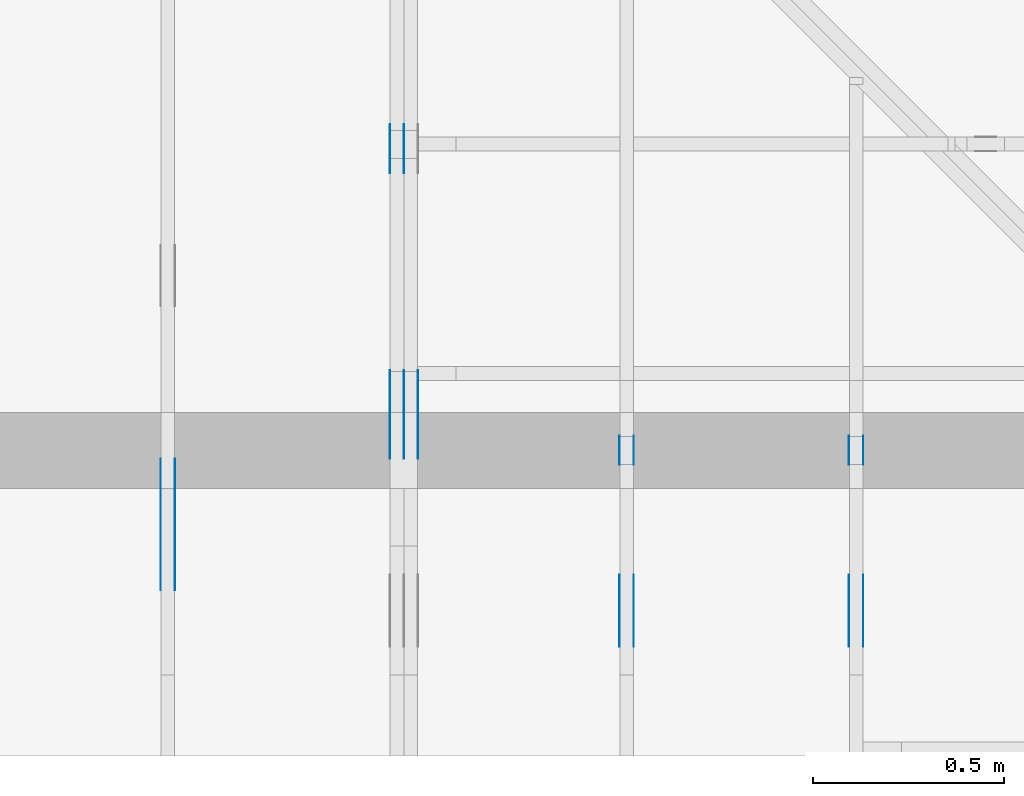
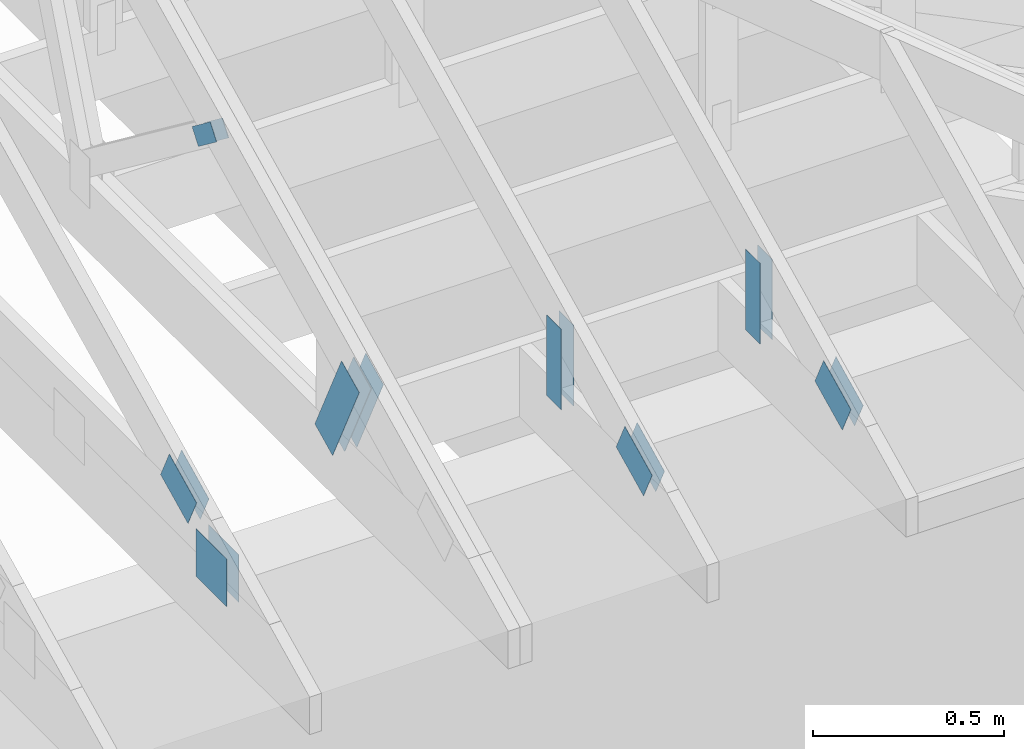
# One storey, part 113 of 159: 19 plates, 4 elements without a shape of their own.
"""IFC2X3 building model written with IfcOpenShell, lengths in millimetres."""

from ifc_helpers import new_model, si_unit, frame, origin, origin_with_axes, origin_2d, place, context, project, spatial, faceted_brep, element, aggregate, save


model = new_model("IFC2X3")

# Units and contexts
model_context = context("Model", 3, precision=1e-05, world=origin())
plan_context = context("Plan", 2, precision=1e-05, world=origin_2d())
ifc_project = project(units=[si_unit("LENGTHUNIT", "METRE", prefix="MILLI"), si_unit("AREAUNIT", "SQUARE_METRE"), si_unit("VOLUMEUNIT", "CUBIC_METRE"), si_unit("SOLIDANGLEUNIT", "STERADIAN"), si_unit("PLANEANGLEUNIT", "RADIAN"), si_unit("MASSUNIT", "GRAM"), si_unit("TIMEUNIT", "SECOND"), si_unit("THERMODYNAMICTEMPERATUREUNIT", "DEGREE_CELSIUS"), si_unit("LUMINOUSINTENSITYUNIT", "LUMEN")], contexts=[model_context, plan_context])

# Site, building, storey
site_placement = place(None, origin_with_axes())
site = spatial("IfcSite", under=ifc_project, at=site_placement, CompositionType="ELEMENT")
building_placement = place(site_placement, origin_with_axes())
building = spatial("IfcBuilding", under=site, at=building_placement, Name="Plan 1", CompositionType="ELEMENT")
storey_placement = place(building_placement, origin_with_axes())
storey = spatial("IfcBuildingStorey", under=building, at=storey_placement, Name="Etasje 1", CompositionType="ELEMENT", Elevation=0.0)

# Assembly, plates
assembly_1_placement = place(storey_placement, frame((18074.541652722903, -699.9989301294845, 4.408582873760558e-15), z_axis=(-1.0, 1.836909530733566e-16, 6.123031769111886e-17), x_axis=(-1.836909530733566e-16, -1.0, 0.0)))
assembly_1 = element("IfcElementAssembly", 1, at=assembly_1_placement, inside=storey, Name="V5 (30)", AssemblyPlace="FACTORY", PredefinedType="TRUSS")
plate_1_placement = place(assembly_1_placement, frame((-916.6453859639496, 125.64558365176572, 0.0), z_axis=(0.0, 0.0, 1.0), x_axis=(0.43837114678907746, 0.898794046299167, 0.0)))
plate_1 = element("IfcPlate", 2, at=plate_1_placement, Name="GNT100S 103x317", context=model_context, shape_type="Brep", body=[
    faceted_brep([(316.99999683746114, 103.0000208490203, 1.0), (1.4939166703697992e-07, 103.0000208490203, 1.0), (5.058774377175723e-07, 0.0, 1.0), (316.99998415240424, 0.0, 1.0), (1.4939166703697992e-07, 103.0000208490203, 1.829459846616026e-23), (316.99999683746114, 103.0000208490203, 3.8820021028882843e-14), (316.99998415240424, 2.5941840476662037e-05, 3.8820019475462714e-14), (5.058774377175723e-07, 2.5941840476662037e-05, 6.19500724484323e-23), (317.00000000000006, 9.031878504152157e-06, -3.395637835881353e-30), (317.00000000000006, 9.031878504213388e-06, 1.0), (1.124750610685991e-32, 9.03187856244342e-06, 1.0), (0.0, 9.03187856238219e-06, 0.0), (317.00000000000006, 103.00000903187856, -3.1554436208840472e-30), (317.00000000000006, 103.00000903187856, 1.0), (317.00000000000006, 9.031878448695352e-06, 1.0), (317.00000000000006, 9.031878448695352e-06, 0.0), (5.684341886080802e-14, 103.00000903187845, 0.0), (5.684341886080802e-14, 103.00000903187845, 1.0), (317.0000000000001, 103.00000903187858, 1.0), (317.0000000000001, 103.00000903187858, 0.0), (1.325156501136875e-22, 9.03187856238219e-06, -8.113975355506237e-39), (6.123045020676898e-17, 9.03187856238219e-06, 1.0), (5.841586450913364e-14, 103.00000903187845, 1.0), (5.835463419144252e-14, 103.00000903187845, -9.253219479443982e-32)], [[[0, 1, 2, 3]], [[4, 5, 6, 7]], [[8, 9, 10, 11]], [[12, 13, 14, 15]], [[16, 17, 18, 19]], [[20, 21, 22, 23]]]),
])
plate_2_placement = place(assembly_1_placement, frame((-916.6453859639496, 125.64558365176572, -37.00000000000001), z_axis=(0.0, 0.0, 1.0), x_axis=(0.43837114678907746, 0.898794046299167, 0.0)))
plate_2 = element("IfcPlate", 3, at=plate_2_placement, Name="GNT100S 103x317", context=model_context, shape_type="Brep", body=[
    faceted_brep([(316.99999683746114, 103.0000208490203, 1.0), (1.4939166703697992e-07, 103.0000208490203, 1.0), (5.058774377175723e-07, 0.0, 1.0), (316.99998415240424, 0.0, 1.0), (1.4939166703697992e-07, 103.0000208490203, 1.829459846616026e-23), (316.99999683746114, 103.0000208490203, 3.8820021028882843e-14), (316.99998415240424, 2.5941840476662037e-05, 3.8820019475462714e-14), (5.058774377175723e-07, 2.5941840476662037e-05, 6.19500724484323e-23), (317.00000000000006, 9.031878504152157e-06, -3.395637835881353e-30), (317.00000000000006, 9.031878504213388e-06, 1.0), (1.124750610685991e-32, 9.03187856244342e-06, 1.0), (0.0, 9.03187856238219e-06, 0.0), (317.00000000000006, 103.00000903187856, -3.1554436208840472e-30), (317.00000000000006, 103.00000903187856, 1.0), (317.00000000000006, 9.031878448695352e-06, 1.0), (317.00000000000006, 9.031878448695352e-06, 0.0), (5.684341886080802e-14, 103.00000903187845, 0.0), (5.684341886080802e-14, 103.00000903187845, 1.0), (317.0000000000001, 103.00000903187858, 1.0), (317.0000000000001, 103.00000903187858, 0.0), (1.325156501136875e-22, 9.03187856238219e-06, -8.113975355506237e-39), (6.123045020676898e-17, 9.03187856238219e-06, 1.0), (5.841586450913364e-14, 103.00000903187845, 1.0), (5.835463419144252e-14, 103.00000903187845, -9.253219479443982e-32)], [[[0, 1, 2, 3]], [[4, 5, 6, 7]], [[8, 9, 10, 11]], [[12, 13, 14, 15]], [[16, 17, 18, 19]], [[20, 21, 22, 23]]]),
])
plate_3_placement = place(assembly_1_placement, frame((-916.6453859639496, 125.64558365176572, -36.00000000000001), z_axis=(0.0, 0.0, 1.0), x_axis=(0.43837114678907746, 0.898794046299167, 0.0)))
plate_3 = element("IfcPlate", 4, at=plate_3_placement, Name="GNT100S 103x317", context=model_context, shape_type="Brep", body=[
    faceted_brep([(316.99999683746114, 103.0000208490203, 1.0), (1.4939166703697992e-07, 103.0000208490203, 1.0), (5.058774377175723e-07, 0.0, 1.0), (316.99998415240424, 0.0, 1.0), (1.4939166703697992e-07, 103.0000208490203, 1.829459846616026e-23), (316.99999683746114, 103.0000208490203, 3.8820021028882843e-14), (316.99998415240424, 2.5941840476662037e-05, 3.8820019475462714e-14), (5.058774377175723e-07, 2.5941840476662037e-05, 6.19500724484323e-23), (317.00000000000006, 9.031878504152157e-06, -3.395637835881353e-30), (317.00000000000006, 9.031878504213388e-06, 1.0), (1.124750610685991e-32, 9.03187856244342e-06, 1.0), (0.0, 9.03187856238219e-06, 0.0), (317.00000000000006, 103.00000903187856, -3.1554436208840472e-30), (317.00000000000006, 103.00000903187856, 1.0), (317.00000000000006, 9.031878448695352e-06, 1.0), (317.00000000000006, 9.031878448695352e-06, 0.0), (5.684341886080802e-14, 103.00000903187845, 0.0), (5.684341886080802e-14, 103.00000903187845, 1.0), (317.0000000000001, 103.00000903187858, 1.0), (317.0000000000001, 103.00000903187858, 0.0), (1.325156501136875e-22, 9.03187856238219e-06, -8.113975355506237e-39), (6.123045020676898e-17, 9.03187856238219e-06, 1.0), (5.841586450913364e-14, 103.00000903187845, 1.0), (5.835463419144252e-14, 103.00000903187845, -9.253219479443982e-32)], [[[0, 1, 2, 3]], [[4, 5, 6, 7]], [[8, 9, 10, 11]], [[12, 13, 14, 15]], [[16, 17, 18, 19]], [[20, 21, 22, 23]]]),
])
plate_4_placement = place(assembly_1_placement, frame((-916.6453859639496, 125.64558365176572, -73.0), z_axis=(0.0, 0.0, 1.0), x_axis=(0.43837114678907746, 0.898794046299167, 0.0)))
plate_4 = element("IfcPlate", 5, at=plate_4_placement, Name="GNT100S 103x317", context=model_context, shape_type="Brep", body=[
    faceted_brep([(316.99999683746114, 103.0000208490203, 1.0), (1.4939166703697992e-07, 103.0000208490203, 1.0), (5.058774377175723e-07, 0.0, 1.0), (316.99998415240424, 0.0, 1.0), (1.4939166703697992e-07, 103.0000208490203, 1.829459846616026e-23), (316.99999683746114, 103.0000208490203, 3.8820021028882843e-14), (316.99998415240424, 2.5941840476662037e-05, 3.8820019475462714e-14), (5.058774377175723e-07, 2.5941840476662037e-05, 6.19500724484323e-23), (317.00000000000006, 9.031878504152157e-06, -3.395637835881353e-30), (317.00000000000006, 9.031878504213388e-06, 1.0), (1.124750610685991e-32, 9.03187856244342e-06, 1.0), (0.0, 9.03187856238219e-06, 0.0), (317.00000000000006, 103.00000903187856, -3.1554436208840472e-30), (317.00000000000006, 103.00000903187856, 1.0), (317.00000000000006, 9.031878448695352e-06, 1.0), (317.00000000000006, 9.031878448695352e-06, 0.0), (5.684341886080802e-14, 103.00000903187845, 0.0), (5.684341886080802e-14, 103.00000903187845, 1.0), (317.0000000000001, 103.00000903187858, 1.0), (317.0000000000001, 103.00000903187858, 0.0), (1.325156501136875e-22, 9.03187856238219e-06, -8.113975355506237e-39), (6.123045020676898e-17, 9.03187856238219e-06, 1.0), (5.841586450913364e-14, 103.00000903187845, 1.0), (5.835463419144252e-14, 103.00000903187845, -9.253219479443982e-32)], [[[0, 1, 2, 3]], [[4, 5, 6, 7]], [[8, 9, 10, 11]], [[12, 13, 14, 15]], [[16, 17, 18, 19]], [[20, 21, 22, 23]]]),
])
plate_5_placement = place(assembly_1_placement, frame((-1556.7082671648463, 802.3749589974988, 0.0), z_axis=(0.0, 0.0, 1.0), x_axis=(-0.7964129491034226, -0.6047531847790378, 0.0)))
plate_5 = element("IfcPlate", 6, at=plate_5_placement, Name="GNT100S 55x119", context=model_context, shape_type="Brep", body=[
    faceted_brep([(119.00002074502436, 54.99999889404717, 1.0), (7.124850799300475e-05, 54.99999889404717, 1.0), (0.0, 2.5153603019134607e-05, 1.0), (119.00004671489364, 2.5153603019134607e-05, 1.0), (7.124850799300475e-05, 54.99999889404717, 8.725137558859805e-21), (119.00002074502436, 54.99999889404717, 1.4572818150935154e-14), (119.00004671489364, 0.0, 1.4572821331221847e-14), (0.0, 0.0, 0.0), (119.0000266606437, 3.217720038807376e-05, 1.3384475843434453e-30), (119.0000266606437, 3.2177200388134993e-05, 1.0), (2.666064369805099e-05, 3.217720040999422e-05, 1.0), (2.666064369805099e-05, 3.2177200409932987e-05, 3.76158192263132e-37), (119.0000266606437, 55.00003217720041, -7.888609052210118e-30), (119.0000266606437, 55.00003217720041, 1.0), (119.0000266606437, 3.217720040993299e-05, 1.0), (119.0000266606437, 3.217720040993299e-05, 0.0), (2.666064369805099e-05, 55.00003217720041, 0.0), (2.666064369805099e-05, 55.00003217720041, 1.0), (119.00002666064381, 55.0000321772004, 1.0), (119.00002666064381, 55.0000321772004, -3.944304526105059e-31), (2.6660643698050993e-05, 3.217720040993299e-05, -1.88079096131566e-37), (2.6660643698112223e-05, 3.217720040993299e-05, 1.0), (2.666064370484756e-05, 55.00003217720041, 1.0), (2.6660643704786328e-05, 55.00003217720041, -4.1240686453966485e-31)], [[[0, 1, 2, 3]], [[4, 5, 6, 7]], [[8, 9, 10, 11]], [[12, 13, 14, 15]], [[16, 17, 18, 19]], [[20, 21, 22, 23]]]),
])
plate_6_placement = place(assembly_1_placement, frame((-1556.7082671648463, 802.3749589974988, -37.0), z_axis=(0.0, 0.0, 1.0), x_axis=(-0.7964129491034226, -0.6047531847790378, 0.0)))
plate_6 = element("IfcPlate", 7, at=plate_6_placement, Name="GNT100S 55x119", context=model_context, shape_type="Brep", body=[
    faceted_brep([(119.00002074502436, 54.99999889404717, 1.0), (7.124850799300475e-05, 54.99999889404717, 1.0), (0.0, 2.5153603019134607e-05, 1.0), (119.00004671489364, 2.5153603019134607e-05, 1.0), (7.124850799300475e-05, 54.99999889404717, 8.725137558859805e-21), (119.00002074502436, 54.99999889404717, 1.4572818150935154e-14), (119.00004671489364, 0.0, 1.4572821331221847e-14), (0.0, 0.0, 0.0), (119.0000266606437, 3.217720038807376e-05, 1.3384475843434453e-30), (119.0000266606437, 3.2177200388134993e-05, 1.0), (2.666064369805099e-05, 3.217720040999422e-05, 1.0), (2.666064369805099e-05, 3.2177200409932987e-05, 3.76158192263132e-37), (119.0000266606437, 55.00003217720041, -7.888609052210118e-30), (119.0000266606437, 55.00003217720041, 1.0), (119.0000266606437, 3.217720040993299e-05, 1.0), (119.0000266606437, 3.217720040993299e-05, 0.0), (2.666064369805099e-05, 55.00003217720041, 0.0), (2.666064369805099e-05, 55.00003217720041, 1.0), (119.00002666064381, 55.0000321772004, 1.0), (119.00002666064381, 55.0000321772004, -3.944304526105059e-31), (2.6660643698050993e-05, 3.217720040993299e-05, -1.88079096131566e-37), (2.6660643698112223e-05, 3.217720040993299e-05, 1.0), (2.666064370484756e-05, 55.00003217720041, 1.0), (2.6660643704786328e-05, 55.00003217720041, -4.1240686453966485e-31)], [[[0, 1, 2, 3]], [[4, 5, 6, 7]], [[8, 9, 10, 11]], [[12, 13, 14, 15]], [[16, 17, 18, 19]], [[20, 21, 22, 23]]]),
])
plate_7_placement = place(assembly_1_placement, frame((-1556.7082671648463, 802.3749589974988, -36.0), z_axis=(0.0, 0.0, 1.0), x_axis=(-0.7964129491034226, -0.6047531847790378, 0.0)))
plate_7 = element("IfcPlate", 8, at=plate_7_placement, Name="GNT100S 55x119", context=model_context, shape_type="Brep", body=[
    faceted_brep([(119.00002074502436, 54.99999889404717, 1.0), (7.124850799300475e-05, 54.99999889404717, 1.0), (0.0, 2.5153603019134607e-05, 1.0), (119.00004671489364, 2.5153603019134607e-05, 1.0), (7.124850799300475e-05, 54.99999889404717, 8.725137558859805e-21), (119.00002074502436, 54.99999889404717, 1.4572818150935154e-14), (119.00004671489364, 0.0, 1.4572821331221847e-14), (0.0, 0.0, 0.0), (119.0000266606437, 3.217720038807376e-05, 1.3384475843434453e-30), (119.0000266606437, 3.2177200388134993e-05, 1.0), (2.666064369805099e-05, 3.217720040999422e-05, 1.0), (2.666064369805099e-05, 3.2177200409932987e-05, 3.76158192263132e-37), (119.0000266606437, 55.00003217720041, -7.888609052210118e-30), (119.0000266606437, 55.00003217720041, 1.0), (119.0000266606437, 3.217720040993299e-05, 1.0), (119.0000266606437, 3.217720040993299e-05, 0.0), (2.666064369805099e-05, 55.00003217720041, 0.0), (2.666064369805099e-05, 55.00003217720041, 1.0), (119.00002666064381, 55.0000321772004, 1.0), (119.00002666064381, 55.0000321772004, -3.944304526105059e-31), (2.6660643698050993e-05, 3.217720040993299e-05, -1.88079096131566e-37), (2.6660643698112223e-05, 3.217720040993299e-05, 1.0), (2.666064370484756e-05, 55.00003217720041, 1.0), (2.6660643704786328e-05, 55.00003217720041, -4.1240686453966485e-31)], [[[0, 1, 2, 3]], [[4, 5, 6, 7]], [[8, 9, 10, 11]], [[12, 13, 14, 15]], [[16, 17, 18, 19]], [[20, 21, 22, 23]]]),
])
aggregate(assembly_1, [plate_1, plate_2, plate_3, plate_4, plate_5, plate_6, plate_7])

assembly_2_placement = place(storey_placement, frame((17475.02226140475, -699.9989301294827, 1.1021457184401395e-15), z_axis=(-1.0, 1.836909530733566e-16, 6.123031769111886e-17), x_axis=(-1.836909530733566e-16, -1.0, 0.0)))
assembly_2 = element("IfcElementAssembly", 9, at=assembly_2_placement, inside=storey, Name="V6 (31)", AssemblyPlace="FACTORY", PredefinedType="TRUSS")
plate_8_placement = place(assembly_2_placement, frame((-589.4027539158434, 382.4373872146755, 0.0), z_axis=(0.0, 0.0, 1.0), x_axis=(-0.898794046299167, 0.4383711467890773, 0.0)))
plate_8 = element("IfcPlate", 10, at=plate_8_placement, Name="GNT100S 103x159", context=model_context, shape_type="Brep", body=[
    faceted_brep([(159.00002333974248, 103.00000256377069, 1.0), (1.0588387681309541e-05, 103.00000256377069, 1.0), (1.1281356478320959e-05, 1.58327808321701e-05, 1.0), (159.00002403271128, 1.58327808321701e-05, 1.0), (1.0588387681309541e-05, 103.00000256377069, 1.2966606831266253e-21), (159.00002333974248, 103.00000256377069, 1.947124388397549e-14), (159.00002403271128, 1.432206761364796e-05, 1.947124396883689e-14), (1.1281356478320959e-05, 1.432206761364796e-05, 1.3815220823087084e-21), (159.0000000000001, -2.9206861538663717e-14, 1.7883454107729003e-30), (159.0000000000001, -2.91456312209726e-14, 1.0), (1.1368683772161603e-13, 6.123031769109798e-17, 1.0), (1.1368683772161603e-13, -2.0883243572979676e-29, 1.2786876383945617e-45), (159.0000000000001, 103.0, 6.310887241768095e-30), (159.0000000000001, 103.0, 1.0), (159.0000000000001, 0.0, 1.0), (159.0000000000001, 0.0, 0.0), (0.0, 103.0, 0.0), (-3.7491518045553436e-33, 103.0, 1.0), (159.0, 102.99999999999999, 1.0), (159.0, 102.99999999999999, -7.888609052210118e-31), (1.1368683772161602e-13, -2.2420775429197073e-44, 1.401298464324817e-45), (1.1374806803930715e-13, 4.6885143195501464e-32, 1.0), (3.487913625456472e-14, 103.0, 1.0), (3.4817905936873604e-14, 103.0, -2.1319114418542637e-30)], [[[0, 1, 2, 3]], [[4, 5, 6, 7]], [[8, 9, 10, 11]], [[12, 13, 14, 15]], [[16, 17, 18, 19]], [[20, 21, 22, 23]]]),
])
plate_9_placement = place(assembly_2_placement, frame((-589.4027539158434, 382.4373872146755, -37.0), z_axis=(0.0, 0.0, 1.0), x_axis=(-0.898794046299167, 0.4383711467890773, 0.0)))
plate_9 = element("IfcPlate", 11, at=plate_9_placement, Name="GNT100S 103x159", context=model_context, shape_type="Brep", body=[
    faceted_brep([(159.00002333974248, 103.00000256377069, 1.0), (1.0588387681309541e-05, 103.00000256377069, 1.0), (1.1281356478320959e-05, 1.58327808321701e-05, 1.0), (159.00002403271128, 1.58327808321701e-05, 1.0), (1.0588387681309541e-05, 103.00000256377069, 1.2966606831266253e-21), (159.00002333974248, 103.00000256377069, 1.947124388397549e-14), (159.00002403271128, 1.432206761364796e-05, 1.947124396883689e-14), (1.1281356478320959e-05, 1.432206761364796e-05, 1.3815220823087084e-21), (159.0000000000001, -2.9206861538663717e-14, 1.7883454107729003e-30), (159.0000000000001, -2.91456312209726e-14, 1.0), (1.1368683772161603e-13, 6.123031769109798e-17, 1.0), (1.1368683772161603e-13, -2.0883243572979676e-29, 1.2786876383945617e-45), (159.0000000000001, 103.0, 6.310887241768095e-30), (159.0000000000001, 103.0, 1.0), (159.0000000000001, 0.0, 1.0), (159.0000000000001, 0.0, 0.0), (0.0, 103.0, 0.0), (-3.7491518045553436e-33, 103.0, 1.0), (159.0, 102.99999999999999, 1.0), (159.0, 102.99999999999999, -7.888609052210118e-31), (1.1368683772161602e-13, -2.2420775429197073e-44, 1.401298464324817e-45), (1.1374806803930715e-13, 4.6885143195501464e-32, 1.0), (3.487913625456472e-14, 103.0, 1.0), (3.4817905936873604e-14, 103.0, -2.1319114418542637e-30)], [[[0, 1, 2, 3]], [[4, 5, 6, 7]], [[8, 9, 10, 11]], [[12, 13, 14, 15]], [[16, 17, 18, 19]], [[20, 21, 22, 23]]]),
])
plate_10_placement = place(assembly_2_placement, frame((-432.9435960219707, 299.0, 0.0), z_axis=(0.0, 0.0, 1.0), x_axis=(-1.0, 1.2246063538223773e-16, 0.0)))
plate_10 = element("IfcPlate", 12, at=plate_10_placement, Name="GNT100S 152x159", context=model_context, shape_type="Brep", body=[
    faceted_brep([(159.00000749365427, 152.0, 1.0), (7.493654265999794e-06, 152.0, 1.0), (7.493654322843213e-06, 0.0, 1.0), (159.00000749365427, 0.0, 1.0), (7.493654265999794e-06, 152.0, 9.17677662749151e-22), (159.00000749365427, 152.0, 1.947124194345346e-14), (159.00000749365427, 0.0, 1.947124194345346e-14), (7.493654322843213e-06, 0.0, 9.176776697102322e-22), (159.0, 1.4132339504376035e-13, 1.788345410772899e-30), (159.0, 1.4138462536145147e-13, 1.0), (5.684341886080802e-14, 1.7059148690011516e-13, 1.0), (5.684341886080802e-14, 1.7053025658242404e-13, 0.0), (159.0, 152.0000000000002, 0.0), (159.0, 152.0000000000002, 1.0), (159.0, 1.7053025658242404e-13, 1.0), (159.0, 1.7053025658242404e-13, 0.0), (0.0, 152.00000000000017, 0.0), (0.0, 152.00000000000017, 1.0), (159.0, 152.0000000000002, 1.0), (159.0, 152.0000000000002, 0.0), (5.684341886080803e-14, 1.7053025658242404e-13, -7.006492321624085e-46), (5.690464917849915e-14, 1.7053025658242404e-13, 1.0), (8.017105859389757e-15, 152.00000000000017, 1.0), (7.955875541698638e-15, 152.00000000000017, -4.871407869292103e-31)], [[[0, 1, 2, 3]], [[4, 5, 6, 7]], [[8, 9, 10, 11]], [[12, 13, 14, 15]], [[16, 17, 18, 19]], [[20, 21, 22, 23]]]),
])
plate_11_placement = place(assembly_2_placement, frame((-432.9435960219707, 299.0, -37.0), z_axis=(0.0, 0.0, 1.0), x_axis=(-1.0, 1.2246063538223773e-16, 0.0)))
plate_11 = element("IfcPlate", 13, at=plate_11_placement, Name="GNT100S 152x159", context=model_context, shape_type="Brep", body=[
    faceted_brep([(159.00000749365427, 152.0, 1.0), (7.493654265999794e-06, 152.0, 1.0), (7.493654322843213e-06, 0.0, 1.0), (159.00000749365427, 0.0, 1.0), (7.493654265999794e-06, 152.0, 9.17677662749151e-22), (159.00000749365427, 152.0, 1.947124194345346e-14), (159.00000749365427, 0.0, 1.947124194345346e-14), (7.493654322843213e-06, 0.0, 9.176776697102322e-22), (159.0, 1.4132339504376035e-13, 1.788345410772899e-30), (159.0, 1.4138462536145147e-13, 1.0), (5.684341886080802e-14, 1.7059148690011516e-13, 1.0), (5.684341886080802e-14, 1.7053025658242404e-13, 0.0), (159.0, 152.0000000000002, 0.0), (159.0, 152.0000000000002, 1.0), (159.0, 1.7053025658242404e-13, 1.0), (159.0, 1.7053025658242404e-13, 0.0), (0.0, 152.00000000000017, 0.0), (0.0, 152.00000000000017, 1.0), (159.0, 152.0000000000002, 1.0), (159.0, 152.0000000000002, 0.0), (5.684341886080803e-14, 1.7053025658242404e-13, -7.006492321624085e-46), (5.690464917849915e-14, 1.7053025658242404e-13, 1.0), (8.017105859389757e-15, 152.00000000000017, 1.0), (7.955875541698638e-15, 152.00000000000017, -4.871407869292103e-31)], [[[0, 1, 2, 3]], [[4, 5, 6, 7]], [[8, 9, 10, 11]], [[12, 13, 14, 15]], [[16, 17, 18, 19]], [[20, 21, 22, 23]]]),
])
aggregate(assembly_2, [plate_8, plate_9, plate_10, plate_11])

assembly_3_placement = place(storey_placement, frame((19311.02226140475, -699.9989301294839, 1.1021457184401395e-15), z_axis=(1.0, -6.123031769111886e-17, 6.123031769111886e-17), x_axis=(6.123031769111886e-17, 1.0, 0.0)))
assembly_3 = element("IfcElementAssembly", 14, at=assembly_3_placement, inside=storey, Name="S23 (53)", AssemblyPlace="FACTORY", PredefinedType="TRUSS")
plate_12_placement = place(assembly_3_placement, frame((331.11001836948736, 141.86159042473707, 0.0), z_axis=(0.0, 0.0, 1.0), x_axis=(0.898794046299167, 0.4383711467890774, 0.0)))
plate_12 = element("IfcPlate", 15, at=plate_12_placement, Name="GNT100S 103x159", context=model_context, shape_type="Brep", body=[
    faceted_brep([(158.9999891856043, 103.00001264929412, 1.0), (1.0552279888997873e-05, 103.00001264929412, 1.0), (3.1702982141723623e-06, 1.220379553501516e-05, 1.0), (159.00000923264014, 1.220379553501516e-05, 1.0), (1.0552279888997873e-05, 103.00001264929412, 1.2922388999378885e-21), (158.9999891856043, 103.00001264929412, 1.947123970143803e-14), (159.00000923264014, 0.0, 1.9471242156410776e-14), (3.1702982141723623e-06, 0.0, 3.8823673365872107e-22), (159.00000000000006, 1.1149522804668519e-05, 3.5286156813378984e-30), (159.00000000000006, 1.114952280472975e-05, 1.0), (1.124750610685991e-32, 1.114952283393661e-05, 1.0), (0.0, 1.114952283387538e-05, 0.0), (159.00000000000006, 103.00001114952286, 0.0), (159.00000000000006, 103.00001114952286, 1.0), (159.00000000000006, 1.114952286229709e-05, 1.0), (159.00000000000006, 1.114952286229709e-05, 0.0), (5.684341886080802e-14, 103.00001114952286, 0.0), (5.684341886080802e-14, 103.00001114952286, 1.0), (159.00000000000006, 103.00001114952285, 1.0), (159.00000000000006, 103.00001114952285, -7.888609052210118e-31), (1.6358571209421976e-22, 1.114952283387538e-05, -1.0016405121256981e-38), (6.123048127683096e-17, 1.114952283387538e-05, 1.0), (5.841586454020379e-14, 103.00001114952286, 1.0), (5.835463422251267e-14, 103.00001114952286, -9.253219669687501e-32)], [[[0, 1, 2, 3]], [[4, 5, 6, 7]], [[8, 9, 10, 11]], [[12, 13, 14, 15]], [[16, 17, 18, 19]], [[20, 21, 22, 23]]]),
])
plate_13_placement = place(assembly_3_placement, frame((331.11001836948736, 141.86159042473707, -37.00000000000001), z_axis=(0.0, 0.0, 1.0), x_axis=(0.898794046299167, 0.4383711467890774, 0.0)))
plate_13 = element("IfcPlate", 16, at=plate_13_placement, Name="GNT100S 103x159", context=model_context, shape_type="Brep", body=[
    faceted_brep([(158.9999891856043, 103.00001264929412, 1.0), (1.0552279888997873e-05, 103.00001264929412, 1.0), (3.1702982141723623e-06, 1.220379553501516e-05, 1.0), (159.00000923264014, 1.220379553501516e-05, 1.0), (1.0552279888997873e-05, 103.00001264929412, 1.2922388999378885e-21), (158.9999891856043, 103.00001264929412, 1.947123970143803e-14), (159.00000923264014, 0.0, 1.9471242156410776e-14), (3.1702982141723623e-06, 0.0, 3.8823673365872107e-22), (159.00000000000006, 1.1149522804668519e-05, 3.5286156813378984e-30), (159.00000000000006, 1.114952280472975e-05, 1.0), (1.124750610685991e-32, 1.114952283393661e-05, 1.0), (0.0, 1.114952283387538e-05, 0.0), (159.00000000000006, 103.00001114952286, 0.0), (159.00000000000006, 103.00001114952286, 1.0), (159.00000000000006, 1.114952286229709e-05, 1.0), (159.00000000000006, 1.114952286229709e-05, 0.0), (5.684341886080802e-14, 103.00001114952286, 0.0), (5.684341886080802e-14, 103.00001114952286, 1.0), (159.00000000000006, 103.00001114952285, 1.0), (159.00000000000006, 103.00001114952285, -7.888609052210118e-31), (1.6358571209421976e-22, 1.114952283387538e-05, -1.0016405121256981e-38), (6.123048127683096e-17, 1.114952283387538e-05, 1.0), (5.841586454020379e-14, 103.00001114952286, 1.0), (5.835463422251267e-14, 103.00001114952286, -9.253219669687501e-32)], [[[0, 1, 2, 3]], [[4, 5, 6, 7]], [[8, 9, 10, 11]], [[12, 13, 14, 15]], [[16, 17, 18, 19]], [[20, 21, 22, 23]]]),
])
plate_14_placement = place(assembly_3_placement, frame((761.0, 413.0166320800781, 0.0), z_axis=(0.0, 0.0, 1.0), x_axis=(6.123031769111886e-17, -1.0, 0.0)))
plate_14 = element("IfcPlate", 17, at=plate_14_placement, Name="GNT100S 76x258", context=model_context, shape_type="Brep", body=[
    faceted_brep([(258.0, 76.0, 1.0), (0.0, 76.0, 1.0), (0.0, 0.0, 1.0), (258.0, 0.0, 1.0), (0.0, 76.0, 0.0), (258.0, 76.0, 3.1594843928617333e-14), (258.0, 0.0, 3.1594843928617333e-14), (0.0, 0.0, 0.0), (258.0000065434458, -4.73922670948978e-14, 2.901843570322951e-30), (258.0000065434458, -4.733103677720668e-14, 1.0), (6.543445806528325e-06, 6.122911571932227e-17, 1.0), (6.543445806528325e-06, -1.2019717965850465e-21, 7.35971149606673e-38), (258.0000065434458, 76.0, 0.0), (258.0000065434458, 76.0, 1.0), (258.0000065434458, 0.0, 1.0), (258.0000065434458, 0.0, 0.0), (6.543445806528325e-06, 76.0, 0.0), (6.543445806528325e-06, 76.0, 1.0), (258.0000065434458, 75.99999999999999, 1.0), (258.0000065434458, 75.99999999999999, -7.888609052210118e-31), (6.543445806528325e-06, 0.0, 0.0), (6.5434458065895555e-06, -7.498303609110687e-33, 1.0), (6.543445815896564e-06, 76.0, 1.0), (6.5434458158353335e-06, 76.0, -5.69871056659997e-31)], [[[0, 1, 2, 3]], [[4, 5, 6, 7]], [[8, 9, 10, 11]], [[12, 13, 14, 15]], [[16, 17, 18, 19]], [[20, 21, 22, 23]]]),
])
plate_15_placement = place(assembly_3_placement, frame((761.0, 413.0166320800781, -37.0), z_axis=(0.0, 0.0, 1.0), x_axis=(6.123031769111886e-17, -1.0, 0.0)))
plate_15 = element("IfcPlate", 18, at=plate_15_placement, Name="GNT100S 76x258", context=model_context, shape_type="Brep", body=[
    faceted_brep([(258.0, 76.0, 1.0), (0.0, 76.0, 1.0), (0.0, 0.0, 1.0), (258.0, 0.0, 1.0), (0.0, 76.0, 0.0), (258.0, 76.0, 3.1594843928617333e-14), (258.0, 0.0, 3.1594843928617333e-14), (0.0, 0.0, 0.0), (258.0000065434458, -4.73922670948978e-14, 2.901843570322951e-30), (258.0000065434458, -4.733103677720668e-14, 1.0), (6.543445806528325e-06, 6.122911571932227e-17, 1.0), (6.543445806528325e-06, -1.2019717965850465e-21, 7.35971149606673e-38), (258.0000065434458, 76.0, 0.0), (258.0000065434458, 76.0, 1.0), (258.0000065434458, 0.0, 1.0), (258.0000065434458, 0.0, 0.0), (6.543445806528325e-06, 76.0, 0.0), (6.543445806528325e-06, 76.0, 1.0), (258.0000065434458, 75.99999999999999, 1.0), (258.0000065434458, 75.99999999999999, -7.888609052210118e-31), (6.543445806528325e-06, 0.0, 0.0), (6.5434458065895555e-06, -7.498303609110687e-33, 1.0), (6.543445815896564e-06, 76.0, 1.0), (6.5434458158353335e-06, 76.0, -5.69871056659997e-31)], [[[0, 1, 2, 3]], [[4, 5, 6, 7]], [[8, 9, 10, 11]], [[12, 13, 14, 15]], [[16, 17, 18, 19]], [[20, 21, 22, 23]]]),
])
aggregate(assembly_3, [plate_12, plate_13, plate_14, plate_15])

assembly_4_placement = place(storey_placement, frame((18711.02226140475, -699.9989301294839, 1.1021457184401395e-15), z_axis=(1.0, -6.123031769111886e-17, 6.123031769111886e-17), x_axis=(6.123031769111886e-17, 1.0, 0.0)))
assembly_4 = element("IfcElementAssembly", 19, at=assembly_4_placement, inside=storey, Name="S24 (52)", AssemblyPlace="FACTORY", PredefinedType="TRUSS")
plate_16_placement = place(assembly_4_placement, frame((331.1100183694874, 141.86159042473707, 0.0), z_axis=(0.0, 0.0, 1.0), x_axis=(0.8987940462991669, 0.43837114678907757, 0.0)))
plate_16 = element("IfcPlate", 20, at=plate_16_placement, Name="GNT100S 103x159", context=model_context, shape_type="Brep", body=[
    faceted_brep([(158.99998918560425, 103.00001264929415, 1.0), (1.0552279832154454e-05, 103.00001264929415, 1.0), (3.1702981004855246e-06, 1.2203795577647725e-05, 1.0), (159.00000923264008, 1.2203795577647725e-05, 1.0), (1.0552279832154454e-05, 103.00001264929415, 1.2922388929768073e-21), (158.99998918560425, 103.00001264929415, 1.9471239701438023e-14), (159.00000923264008, 0.0, 1.947124215641077e-14), (3.1702981004855246e-06, 0.0, 3.882367197365587e-22), (159.0, 1.1149522762035955e-05, -8.220600630328674e-31), (159.0, 1.1149522762097185e-05, 1.0), (1.124750610685991e-32, 1.1149522791304047e-05, 1.0), (0.0, 1.1149522791242816e-05, 0.0), (159.0, 103.00001114952275, 0.0), (159.0, 103.00001114952275, 1.0), (159.0, 1.1149522748610252e-05, 1.0), (159.0, 1.1149522748610252e-05, 0.0), (0.0, 103.00001114952279, 0.0), (0.0, 103.00001114952279, 1.0), (159.0, 103.00001114952275, 1.0), (159.0, 103.00001114952275, 7.888609052210118e-31), (1.365377645224336e-21, 1.1149522791242816e-05, -8.360250698543787e-38), (6.123168306876408e-17, 1.1149522791242816e-05, 1.0), (1.267467712743925e-14, 103.00001114952279, 1.0), (1.2613446809748131e-14, 103.00001114952279, -7.723253553409078e-31)], [[[0, 1, 2, 3]], [[4, 5, 6, 7]], [[8, 9, 10, 11]], [[12, 13, 14, 15]], [[16, 17, 18, 19]], [[20, 21, 22, 23]]]),
])
plate_17_placement = place(assembly_4_placement, frame((331.1100183694874, 141.86159042473707, -37.0), z_axis=(0.0, 0.0, 1.0), x_axis=(0.8987940462991669, 0.43837114678907757, 0.0)))
plate_17 = element("IfcPlate", 21, at=plate_17_placement, Name="GNT100S 103x159", context=model_context, shape_type="Brep", body=[
    faceted_brep([(158.99998918560425, 103.00001264929415, 1.0), (1.0552279832154454e-05, 103.00001264929415, 1.0), (3.1702981004855246e-06, 1.2203795577647725e-05, 1.0), (159.00000923264008, 1.2203795577647725e-05, 1.0), (1.0552279832154454e-05, 103.00001264929415, 1.2922388929768073e-21), (158.99998918560425, 103.00001264929415, 1.9471239701438023e-14), (159.00000923264008, 0.0, 1.947124215641077e-14), (3.1702981004855246e-06, 0.0, 3.882367197365587e-22), (159.0, 1.1149522762035955e-05, -8.220600630328674e-31), (159.0, 1.1149522762097185e-05, 1.0), (1.124750610685991e-32, 1.1149522791304047e-05, 1.0), (0.0, 1.1149522791242816e-05, 0.0), (159.0, 103.00001114952275, 0.0), (159.0, 103.00001114952275, 1.0), (159.0, 1.1149522748610252e-05, 1.0), (159.0, 1.1149522748610252e-05, 0.0), (0.0, 103.00001114952279, 0.0), (0.0, 103.00001114952279, 1.0), (159.0, 103.00001114952275, 1.0), (159.0, 103.00001114952275, 7.888609052210118e-31), (1.365377645224336e-21, 1.1149522791242816e-05, -8.360250698543787e-38), (6.123168306876408e-17, 1.1149522791242816e-05, 1.0), (1.267467712743925e-14, 103.00001114952279, 1.0), (1.2613446809748131e-14, 103.00001114952279, -7.723253553409078e-31)], [[[0, 1, 2, 3]], [[4, 5, 6, 7]], [[8, 9, 10, 11]], [[12, 13, 14, 15]], [[16, 17, 18, 19]], [[20, 21, 22, 23]]]),
])
plate_18_placement = place(assembly_4_placement, frame((761.0, 413.0166320800781, 0.0), z_axis=(0.0, 0.0, 1.0), x_axis=(6.123031769111886e-17, -1.0, 0.0)))
plate_18 = element("IfcPlate", 22, at=plate_18_placement, Name="GNT100S 76x258", context=model_context, shape_type="Brep", body=[
    faceted_brep([(258.0, 76.0, 1.0), (0.0, 76.0, 1.0), (0.0, 0.0, 1.0), (258.0, 0.0, 1.0), (0.0, 76.0, 0.0), (258.0, 76.0, 3.1594843928617333e-14), (258.0, 0.0, 3.1594843928617333e-14), (0.0, 0.0, 0.0), (258.0000065433729, -4.73922670948844e-14, 2.9018435703221308e-30), (258.0000065433729, -4.733103677719328e-14, 1.0), (6.543372876421927e-06, 6.122911573271888e-17, 1.0), (6.543372876421927e-06, -1.2019583999842945e-21, 7.359629468254727e-38), (258.0000065433729, 76.0, 0.0), (258.0000065433729, 76.0, 1.0), (258.0000065433729, 0.0, 1.0), (258.0000065433729, 0.0, 0.0), (6.543372876421927e-06, 76.0, 0.0), (6.543372876421927e-06, 76.0, 1.0), (258.0000065433729, 75.99999999999999, 1.0), (258.0000065433729, 75.99999999999999, -7.888609052210118e-31), (6.543372876421927e-06, 0.0, 0.0), (6.543372876483157e-06, -7.498303609110687e-33, 1.0), (6.543372885790165e-06, 76.0, 1.0), (6.543372885728935e-06, 76.0, -5.69871056659997e-31)], [[[0, 1, 2, 3]], [[4, 5, 6, 7]], [[8, 9, 10, 11]], [[12, 13, 14, 15]], [[16, 17, 18, 19]], [[20, 21, 22, 23]]]),
])
plate_19_placement = place(assembly_4_placement, frame((761.0, 413.0166320800781, -37.0), z_axis=(0.0, 0.0, 1.0), x_axis=(6.123031769111886e-17, -1.0, 0.0)))
plate_19 = element("IfcPlate", 23, at=plate_19_placement, Name="GNT100S 76x258", context=model_context, shape_type="Brep", body=[
    faceted_brep([(258.0, 76.0, 1.0), (0.0, 76.0, 1.0), (0.0, 0.0, 1.0), (258.0, 0.0, 1.0), (0.0, 76.0, 0.0), (258.0, 76.0, 3.1594843928617333e-14), (258.0, 0.0, 3.1594843928617333e-14), (0.0, 0.0, 0.0), (258.0000065433729, -4.73922670948844e-14, 2.9018435703221308e-30), (258.0000065433729, -4.733103677719328e-14, 1.0), (6.543372876421927e-06, 6.122911573271888e-17, 1.0), (6.543372876421927e-06, -1.2019583999842945e-21, 7.359629468254727e-38), (258.0000065433729, 76.0, 0.0), (258.0000065433729, 76.0, 1.0), (258.0000065433729, 0.0, 1.0), (258.0000065433729, 0.0, 0.0), (6.543372876421927e-06, 76.0, 0.0), (6.543372876421927e-06, 76.0, 1.0), (258.0000065433729, 75.99999999999999, 1.0), (258.0000065433729, 75.99999999999999, -7.888609052210118e-31), (6.543372876421927e-06, 0.0, 0.0), (6.543372876483157e-06, -7.498303609110687e-33, 1.0), (6.543372885790165e-06, 76.0, 1.0), (6.543372885728935e-06, 76.0, -5.69871056659997e-31)], [[[0, 1, 2, 3]], [[4, 5, 6, 7]], [[8, 9, 10, 11]], [[12, 13, 14, 15]], [[16, 17, 18, 19]], [[20, 21, 22, 23]]]),
])
aggregate(assembly_4, [plate_16, plate_17, plate_18, plate_19])

save(model, "model.ifc")
